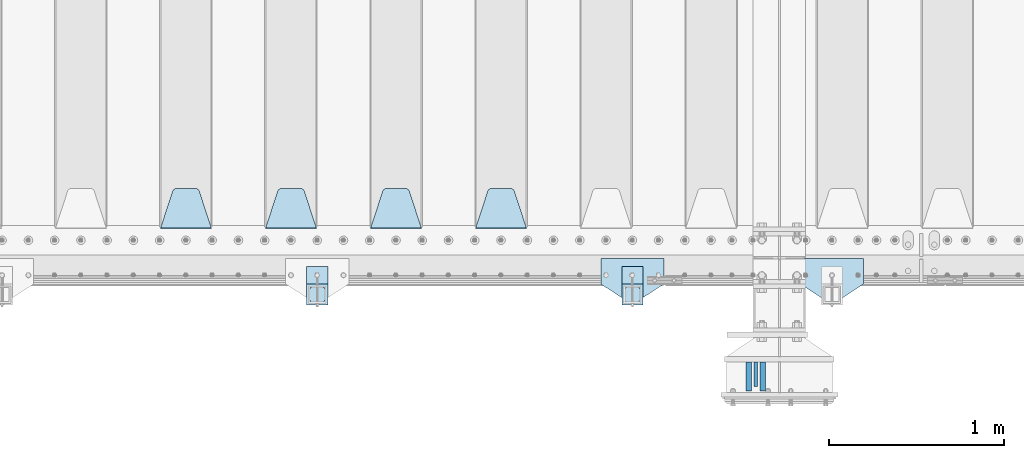
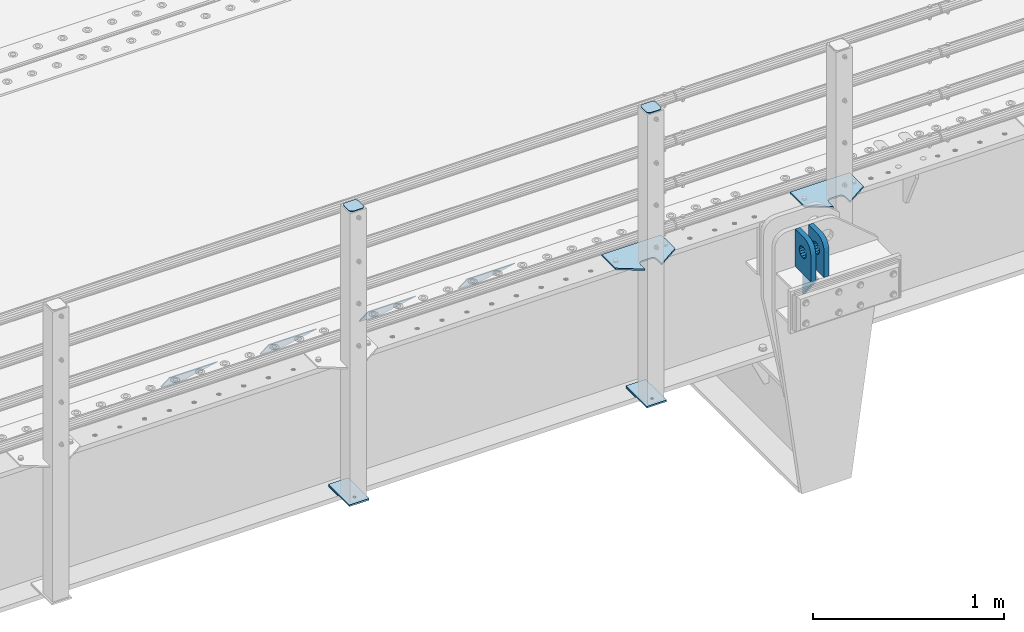
# One storey, part 181 of 219: 15 plates.
"""IFC2X3 building model written with IfcOpenShell, lengths in millimetres."""

from ifc_helpers import new_model, si_unit, frame, origin_with_axes, place, context, subcontext, project, spatial, faceted_brep, material, type_object, element, save


model = new_model("IFC2X3")

# Units and contexts
model_context = context("Model", 3, precision=1e-05, world=origin_with_axes())
body_context = subcontext(model_context, "Body", "Model", "MODEL_VIEW")
ifc_project = project(units=[si_unit("LENGTHUNIT", "METRE", prefix="MILLI"), si_unit("AREAUNIT", "SQUARE_METRE"), si_unit("VOLUMEUNIT", "CUBIC_METRE"), si_unit("MASSUNIT", "GRAM", prefix="KILO"), si_unit("TIMEUNIT", "SECOND"), si_unit("PLANEANGLEUNIT", "RADIAN"), si_unit("SOLIDANGLEUNIT", "STERADIAN"), si_unit("THERMODYNAMICTEMPERATUREUNIT", "DEGREE_CELSIUS"), si_unit("LUMINOUSINTENSITYUNIT", "LUMEN")], contexts=[model_context])

# Site, building, storey
site_placement = place(None, origin_with_axes())
site = spatial("IfcSite", under=ifc_project, at=site_placement, CompositionType="ELEMENT")
building_placement = place(site_placement, origin_with_axes())
building = spatial("IfcBuilding", under=site, at=building_placement, Name="Standard", CompositionType="ELEMENT")
storey_placement = place(building_placement, origin_with_axes())
storey = spatial("IfcBuildingStorey", under=building, at=storey_placement, Name="Undefined", CompositionType="ELEMENT", Elevation=0.0)

# Plates
ifc_material_1 = material(Name="STEEL/S355N")
plate_type_1 = type_object("IfcPlateType", PredefinedType="NOTDEFINED")
plate_1_placement = place(storey_placement, frame((10294.4999999602, 23404.9999999862, -1.8238333723275e-05), z_axis=(0.0, -1.0, 0.0), x_axis=(0.0, 0.0, 1.0)))
element("IfcPlate", 1, at=plate_1_placement, inside=storey, type_object=plate_type_1, material=ifc_material_1, context=body_context, shape_type="Brep", body=[
    faceted_brep([(113.837049096098, 15.0, 53.8370490960951), (113.837049096098, -15.0, 53.8370490960951), (125.840713002492, -15.0, 45.8164572970854), (125.840713002492, 15.0, 45.8164572970854), (105.816457297082, 15.0, 65.8407130024934), (105.816457297082, -15.0, 65.8407130024934), (103.0, 15.0, 80.0), (103.0, -15.0, 80.0), (105.816457297082, 15.0, 94.1592869975066), (105.816457297082, -15.0, 94.1592869975066), (113.837049096098, 15.0, 106.162950903905), (113.837049096098, -15.0, 106.162950903905), (125.840713002492, 15.0, 114.183542702915), (125.840713002492, -15.0, 114.183542702915), (140.0, 15.0, 117.0), (140.0, -15.0, 117.0), (154.159286997508, 15.0, 114.183542702915), (154.159286997508, -15.0, 114.183542702915), (166.162950903902, 15.0, 106.162950903905), (166.162950903902, -15.0, 106.162950903905), (174.183542702918, 15.0, 94.1592869975066), (174.183542702918, -15.0, 94.1592869975066), (177.0, 15.0, 80.0), (177.0, -15.0, 80.0), (174.183542702918, 15.0, 65.8407130024934), (174.183542702918, -15.0, 65.8407130024934), (166.162950903902, 15.0, 53.8370490960951), (166.162950903902, -15.0, 53.8370490960951), (154.159286997508, 15.0, 45.8164572970854), (154.159286997508, -15.0, 45.8164572970854), (140.0, 15.0, 43.0), (140.0, -15.0, 43.0), (240.0, -15.0, 0.0), (240.001666876698, -15.0000000000018, 94.9959403776193), (237.616787699976, -15.0000000000018, 113.113322498932), (230.624045898169, -15.0000000000018, 129.996116868064), (219.499985670386, -15.0000000000018, 144.49378797986), (205.002693976271, -15.0000000000018, 155.61834267445), (188.120138118986, -15.0000000000018, 162.611660295064), (170.002837349484, -15.0000000000018, 164.99715740146), (0.0, -15.0, 165.0), (0.0, -15.0, 0.0), (0.0, 15.0, 0.0), (240.0, 15.0, 0.0), (240.001666876698, 14.9999999999982, 94.9959403776229), (237.616787699976, 14.9999999999982, 113.113322498932), (230.624045898169, 14.9999999999982, 129.996116868064), (219.499985670386, 14.9999999999982, 144.49378797986), (205.002693976271, 14.9999999999982, 155.61834267445), (188.120138118986, 14.9999999999982, 162.611660295064), (170.002837349484, 14.9999999999982, 164.99715740146), (0.0, 15.0, 165.0)], [[[0, 1, 2, 3]], [[4, 5, 1, 0]], [[6, 7, 5, 4]], [[8, 9, 7, 6]], [[10, 11, 9, 8]], [[12, 13, 11, 10]], [[14, 15, 13, 12]], [[16, 17, 15, 14]], [[18, 19, 17, 16]], [[20, 21, 19, 18]], [[22, 23, 21, 20]], [[24, 25, 23, 22]], [[26, 27, 25, 24]], [[28, 29, 27, 26]], [[30, 31, 29, 28]], [[3, 2, 31, 30]], [[32, 33, 34, 35, 36, 37, 38, 39, 40, 41], [19, 21, 23, 25, 27, 29, 31, 2, 1, 5, 7, 9, 11, 13, 15, 17]], [[32, 41, 42, 43]], [[33, 32, 43, 44]], [[34, 33, 44, 45]], [[35, 34, 45, 46]], [[36, 35, 46, 47]], [[37, 36, 47, 48]], [[38, 37, 48, 49]], [[39, 38, 49, 50]], [[40, 39, 50, 51]], [[41, 40, 51, 42]], [[50, 49, 48, 47, 46, 45, 44, 43, 42, 51], [10, 8, 6, 4, 0, 3, 30, 28, 26, 24, 22, 20, 18, 16, 14, 12]]]),
])
plate_2_placement = place(storey_placement, frame((10214.4999999619, 23404.9999999862, -1.8238333723275e-05), z_axis=(0.0, -1.0, 0.0), x_axis=(0.0, 0.0, 1.0)))
element("IfcPlate", 2, at=plate_2_placement, inside=storey, type_object=plate_type_1, material=ifc_material_1, context=body_context, shape_type="Brep", body=[
    faceted_brep([(113.837049096098, 15.0, 53.8370490960951), (113.837049096098, -15.0, 53.8370490960951), (125.840713002492, -15.0, 45.8164572970854), (125.840713002492, 15.0, 45.8164572970854), (105.816457297082, 15.0, 65.8407130024934), (105.816457297082, -15.0, 65.8407130024934), (103.0, 15.0, 80.0), (103.0, -15.0, 80.0), (105.816457297082, 15.0, 94.1592869975066), (105.816457297082, -15.0, 94.1592869975066), (113.837049096098, 15.0, 106.162950903905), (113.837049096098, -15.0, 106.162950903905), (125.840713002492, 15.0, 114.183542702915), (125.840713002492, -15.0, 114.183542702915), (140.0, 15.0, 117.0), (140.0, -15.0, 117.0), (154.159286997508, 15.0, 114.183542702915), (154.159286997508, -15.0, 114.183542702915), (166.162950903902, 15.0, 106.162950903905), (166.162950903902, -15.0, 106.162950903905), (174.183542702918, 15.0, 94.1592869975066), (174.183542702918, -15.0, 94.1592869975066), (177.0, 15.0, 80.0), (177.0, -15.0, 80.0), (174.183542702918, 15.0, 65.8407130024934), (174.183542702918, -15.0, 65.8407130024934), (166.162950903902, 15.0, 53.8370490960951), (166.162950903902, -15.0, 53.8370490960951), (154.159286997508, 15.0, 45.8164572970854), (154.159286997508, -15.0, 45.8164572970854), (140.0, 15.0, 43.0), (140.0, -15.0, 43.0), (240.0, -15.0, 0.0), (240.0, -15.0, 95.0), (237.614807840235, -15.0, 113.117333157177), (230.621778264911, -15.0, 130.0), (219.497474683058, -15.0, 144.497474683056), (205.0, -15.0, 155.621778264911), (188.117333157176, -15.0, 162.614807840233), (170.0, -15.0, 165.0), (0.0, -15.0, 165.0), (0.0, -15.0, 0.0), (0.0, 15.0, 0.0), (240.0, 15.0, 0.0), (240.0, 15.0, 95.0), (237.614807840235, 15.0, 113.117333157177), (230.621778264911, 15.0, 130.0), (219.497474683058, 15.0, 144.497474683056), (205.0, 15.0, 155.621778264911), (188.117333157176, 15.0, 162.614807840233), (170.0, 15.0, 165.0), (0.0, 15.0, 165.0)], [[[0, 1, 2, 3]], [[4, 5, 1, 0]], [[6, 7, 5, 4]], [[8, 9, 7, 6]], [[10, 11, 9, 8]], [[12, 13, 11, 10]], [[14, 15, 13, 12]], [[16, 17, 15, 14]], [[18, 19, 17, 16]], [[20, 21, 19, 18]], [[22, 23, 21, 20]], [[24, 25, 23, 22]], [[26, 27, 25, 24]], [[28, 29, 27, 26]], [[30, 31, 29, 28]], [[3, 2, 31, 30]], [[32, 33, 34, 35, 36, 37, 38, 39, 40, 41], [19, 21, 23, 25, 27, 29, 31, 2, 1, 5, 7, 9, 11, 13, 15, 17]], [[32, 41, 42, 43]], [[33, 32, 43, 44]], [[34, 33, 44, 45]], [[35, 34, 45, 46]], [[36, 35, 46, 47]], [[37, 36, 47, 48]], [[38, 37, 48, 49]], [[39, 38, 49, 50]], [[40, 39, 50, 51]], [[41, 40, 51, 42]], [[50, 49, 48, 47, 46, 45, 44, 43, 42, 51], [10, 8, 6, 4, 0, 3, 30, 28, 26, 24, 22, 20, 18, 16, 14, 12]]]),
])
plate_type_2 = type_object("IfcPlateType", PredefinedType="NOTDEFINED")
plate_3_placement = place(storey_placement, frame((10254.4999999618, 23264.9999999862, -14.000018238301), z_axis=(0.0, 0.0, -1.0), x_axis=(0.0, 1.0, 0.0)))
element("IfcPlate", 3, at=plate_3_placement, inside=storey, type_object=plate_type_2, material=ifc_material_1, context=body_context, shape_type="Brep", body=[
    faceted_brep([(0.0, -10.0, 0.0), (140.0, -10.0, 180.0), (140.0, 10.0, 180.0), (0.0, 10.0, 0.0), (140.0, -10.0, -1.81898940354586e-12), (140.0, 10.0, -1.81898940354586e-12)], [[[0, 1, 2, 3]], [[1, 4, 5, 2]], [[4, 0, 3, 5]], [[5, 3, 2]], [[4, 1, 0]]]),
])
plate_type_3 = type_object("IfcPlateType", PredefinedType="NOTDEFINED")
plate_4_placement = place(storey_placement, frame((8945.0, 24168.232233047, -1.76776695296758), z_axis=(0.0, 0.707106781186547, -0.707106781186548), x_axis=(-1.0, 0.0, 0.0)))
element("IfcPlate", 4, at=plate_4_placement, inside=storey, type_object=plate_type_3, material=ifc_material_1, context=body_context, shape_type="Brep", body=[
    faceted_brep([(0.0, -2.5, 0.0), (69.345504679477, -2.5, 300.171731424834), (69.345504679477, 2.49999999999636, 300.171731424831), (0.0, 2.5, 0.0), (70.9274061199576, -2.50000000000364, 304.8974424154), (70.9274061199576, 2.49999999999636, 304.8974424154), (73.3818627772307, -2.50000000000364, 309.234538108532), (73.3818627772307, 2.49999999999636, 309.234538108532), (76.6187032999569, -2.50000000000364, 313.023683126106), (76.6187032999569, 2.49999999999636, 313.023683126106), (80.5190132704993, -2.50000000000364, 316.125672595372), (80.5190132704993, 2.49999999999636, 316.125672595372), (84.9395038596831, -2.50000000000364, 318.426546230476), (84.9395038596831, 2.5, 318.426546230479), (89.7177759439237, -2.50000000000364, 319.841774983277), (89.7177759439237, 2.5, 319.841774983281), (94.6782862926502, -2.50000000000364, 320.319366455078), (94.6782862926502, 2.49999999999636, 320.319366455078), (195.32171370735, -2.50000000000364, 320.319366455078), (195.32171370735, 2.49999999999636, 320.319366455078), (200.282224056076, -2.50000000000364, 319.841774983277), (200.282224056076, 2.5, 319.841774983281), (205.060496140317, -2.50000000000364, 318.426546230476), (205.060496140317, 2.49999999999636, 318.426546230476), (209.480986729501, -2.50000000000364, 316.125672595372), (209.480986729501, 2.49999999999636, 316.125672595372), (213.381296700043, -2.50000000000364, 313.023683126106), (213.381296700043, 2.49999999999272, 313.023683126106), (216.618137222769, -2.50000000000364, 309.234538108529), (216.618137222769, 2.49999999999636, 309.234538108525), (219.072593880042, -2.50000000000364, 304.8974424154), (219.072593880042, 2.49999999999636, 304.8974424154), (220.654495320523, -2.5, 300.171731424834), (220.654495320523, 2.49999999999636, 300.171731424831), (290.0, -2.50000000000364, 3.63797880709171e-12), (290.0, 2.49999999999636, 0.0)], [[[0, 1, 2, 3]], [[1, 4, 5, 2]], [[4, 6, 7, 5]], [[6, 8, 9, 7]], [[8, 10, 11, 9]], [[10, 12, 13, 11]], [[12, 14, 15, 13]], [[14, 16, 17, 15]], [[16, 18, 19, 17]], [[18, 20, 21, 19]], [[20, 22, 23, 21]], [[22, 24, 25, 23]], [[24, 26, 27, 25]], [[26, 28, 29, 27]], [[28, 30, 31, 29]], [[30, 32, 33, 31]], [[32, 34, 35, 33]], [[34, 0, 3, 35]], [[5, 7, 9, 11, 13, 15, 17, 19, 21, 23, 25, 27, 29, 31, 33, 35, 3, 2]], [[34, 32, 30, 28, 26, 24, 22, 20, 18, 16, 14, 12, 10, 8, 6, 4, 1, 0]]]),
])
plate_5_placement = place(storey_placement, frame((8345.0, 24168.232233047, -1.76776695296758), z_axis=(0.0, 0.707106781186547, -0.707106781186548), x_axis=(-1.0, 0.0, 0.0)))
element("IfcPlate", 5, at=plate_5_placement, inside=storey, type_object=plate_type_3, material=ifc_material_1, context=body_context, shape_type="Brep", body=[
    faceted_brep([(0.0, -2.5, 0.0), (69.345504679477, -2.5, 300.171731424834), (69.345504679477, 2.49999999999636, 300.171731424831), (0.0, 2.5, 0.0), (70.9274061199576, -2.50000000000364, 304.8974424154), (70.9274061199576, 2.49999999999636, 304.8974424154), (73.3818627772307, -2.50000000000364, 309.234538108532), (73.3818627772307, 2.49999999999636, 309.234538108532), (76.6187032999569, -2.50000000000364, 313.023683126106), (76.6187032999569, 2.49999999999636, 313.023683126106), (80.5190132704993, -2.50000000000364, 316.125672595372), (80.5190132704993, 2.49999999999636, 316.125672595372), (84.9395038596831, -2.50000000000364, 318.426546230476), (84.9395038596831, 2.5, 318.426546230479), (89.7177759439237, -2.50000000000364, 319.841774983277), (89.7177759439237, 2.5, 319.841774983281), (94.6782862926502, -2.50000000000364, 320.319366455078), (94.6782862926502, 2.49999999999636, 320.319366455078), (195.32171370735, -2.50000000000364, 320.319366455078), (195.32171370735, 2.49999999999636, 320.319366455078), (200.282224056076, -2.50000000000364, 319.841774983277), (200.282224056076, 2.5, 319.841774983281), (205.060496140317, -2.50000000000364, 318.426546230476), (205.060496140317, 2.49999999999636, 318.426546230476), (209.480986729501, -2.50000000000364, 316.125672595372), (209.480986729501, 2.49999999999636, 316.125672595372), (213.381296700043, -2.50000000000364, 313.023683126106), (213.381296700043, 2.49999999999272, 313.023683126106), (216.618137222769, -2.50000000000364, 309.234538108529), (216.618137222769, 2.49999999999636, 309.234538108525), (219.072593880042, -2.50000000000364, 304.8974424154), (219.072593880042, 2.49999999999636, 304.8974424154), (220.654495320523, -2.5, 300.171731424834), (220.654495320523, 2.49999999999636, 300.171731424831), (290.0, -2.50000000000364, 3.63797880709171e-12), (290.0, 2.49999999999636, 0.0)], [[[0, 1, 2, 3]], [[1, 4, 5, 2]], [[4, 6, 7, 5]], [[6, 8, 9, 7]], [[8, 10, 11, 9]], [[10, 12, 13, 11]], [[12, 14, 15, 13]], [[14, 16, 17, 15]], [[16, 18, 19, 17]], [[18, 20, 21, 19]], [[20, 22, 23, 21]], [[22, 24, 25, 23]], [[24, 26, 27, 25]], [[26, 28, 29, 27]], [[28, 30, 31, 29]], [[30, 32, 33, 31]], [[32, 34, 35, 33]], [[34, 0, 3, 35]], [[5, 7, 9, 11, 13, 15, 17, 19, 21, 23, 25, 27, 29, 31, 33, 35, 3, 2]], [[34, 32, 30, 28, 26, 24, 22, 20, 18, 16, 14, 12, 10, 8, 6, 4, 1, 0]]]),
])
plate_6_placement = place(storey_placement, frame((7745.0, 24168.232233047, -1.76776695296758), z_axis=(0.0, 0.707106781186547, -0.707106781186548), x_axis=(-1.0, 0.0, 0.0)))
element("IfcPlate", 6, at=plate_6_placement, inside=storey, type_object=plate_type_3, material=ifc_material_1, context=body_context, shape_type="Brep", body=[
    faceted_brep([(0.0, -2.5, 0.0), (69.345504679477, -2.5, 300.171731424834), (69.345504679477, 2.49999999999636, 300.171731424831), (0.0, 2.5, 0.0), (70.9274061199576, -2.50000000000364, 304.8974424154), (70.9274061199576, 2.49999999999636, 304.8974424154), (73.3818627772307, -2.50000000000364, 309.234538108532), (73.3818627772307, 2.49999999999636, 309.234538108532), (76.6187032999569, -2.50000000000364, 313.023683126106), (76.6187032999569, 2.49999999999636, 313.023683126106), (80.5190132704993, -2.50000000000364, 316.125672595372), (80.5190132704993, 2.49999999999636, 316.125672595372), (84.9395038596831, -2.50000000000364, 318.426546230476), (84.9395038596831, 2.5, 318.426546230479), (89.7177759439237, -2.50000000000364, 319.841774983277), (89.7177759439237, 2.5, 319.841774983281), (94.6782862926502, -2.50000000000364, 320.319366455078), (94.6782862926502, 2.49999999999636, 320.319366455078), (195.32171370735, -2.50000000000364, 320.319366455078), (195.32171370735, 2.49999999999636, 320.319366455078), (200.282224056076, -2.50000000000364, 319.841774983277), (200.282224056076, 2.5, 319.841774983281), (205.060496140317, -2.50000000000364, 318.426546230476), (205.060496140317, 2.49999999999636, 318.426546230476), (209.480986729501, -2.50000000000364, 316.125672595372), (209.480986729501, 2.49999999999636, 316.125672595372), (213.381296700043, -2.50000000000364, 313.023683126106), (213.381296700043, 2.49999999999272, 313.023683126106), (216.618137222769, -2.50000000000364, 309.234538108529), (216.618137222769, 2.49999999999636, 309.234538108525), (219.072593880042, -2.50000000000364, 304.8974424154), (219.072593880042, 2.49999999999636, 304.8974424154), (220.654495320523, -2.5, 300.171731424834), (220.654495320523, 2.49999999999636, 300.171731424831), (290.0, -2.50000000000364, 3.63797880709171e-12), (290.0, 2.49999999999636, 0.0)], [[[0, 1, 2, 3]], [[1, 4, 5, 2]], [[4, 6, 7, 5]], [[6, 8, 9, 7]], [[8, 10, 11, 9]], [[10, 12, 13, 11]], [[12, 14, 15, 13]], [[14, 16, 17, 15]], [[16, 18, 19, 17]], [[18, 20, 21, 19]], [[20, 22, 23, 21]], [[22, 24, 25, 23]], [[24, 26, 27, 25]], [[26, 28, 29, 27]], [[28, 30, 31, 29]], [[30, 32, 33, 31]], [[32, 34, 35, 33]], [[34, 0, 3, 35]], [[5, 7, 9, 11, 13, 15, 17, 19, 21, 23, 25, 27, 29, 31, 33, 35, 3, 2]], [[34, 32, 30, 28, 26, 24, 22, 20, 18, 16, 14, 12, 10, 8, 6, 4, 1, 0]]]),
])
plate_7_placement = place(storey_placement, frame((7145.0, 24168.232233047, -1.76776695296758), z_axis=(0.0, 0.707106781186547, -0.707106781186548), x_axis=(-1.0, 0.0, 0.0)))
element("IfcPlate", 7, at=plate_7_placement, inside=storey, type_object=plate_type_3, material=ifc_material_1, context=body_context, shape_type="Brep", body=[
    faceted_brep([(0.0, -2.5, 0.0), (69.345504679477, -2.5, 300.171731424834), (69.345504679477, 2.49999999999636, 300.171731424831), (0.0, 2.5, 0.0), (70.9274061199576, -2.50000000000364, 304.8974424154), (70.9274061199576, 2.49999999999636, 304.8974424154), (73.3818627772307, -2.50000000000364, 309.234538108532), (73.3818627772307, 2.49999999999636, 309.234538108532), (76.6187032999569, -2.50000000000364, 313.023683126106), (76.6187032999569, 2.49999999999636, 313.023683126106), (80.5190132704993, -2.50000000000364, 316.125672595372), (80.5190132704993, 2.49999999999636, 316.125672595372), (84.9395038596831, -2.50000000000364, 318.426546230476), (84.9395038596831, 2.5, 318.426546230479), (89.7177759439237, -2.50000000000364, 319.841774983277), (89.7177759439237, 2.5, 319.841774983281), (94.6782862926502, -2.50000000000364, 320.319366455078), (94.6782862926502, 2.49999999999636, 320.319366455078), (195.32171370735, -2.50000000000364, 320.319366455078), (195.32171370735, 2.49999999999636, 320.319366455078), (200.282224056076, -2.50000000000364, 319.841774983277), (200.282224056076, 2.5, 319.841774983281), (205.060496140317, -2.50000000000364, 318.426546230476), (205.060496140317, 2.49999999999636, 318.426546230476), (209.480986729501, -2.50000000000364, 316.125672595372), (209.480986729501, 2.49999999999636, 316.125672595372), (213.381296700043, -2.50000000000364, 313.023683126106), (213.381296700043, 2.49999999999272, 313.023683126106), (216.618137222769, -2.50000000000364, 309.234538108529), (216.618137222769, 2.49999999999636, 309.234538108525), (219.072593880042, -2.50000000000364, 304.8974424154), (219.072593880042, 2.49999999999636, 304.8974424154), (220.654495320523, -2.5, 300.171731424834), (220.654495320523, 2.49999999999636, 300.171731424831), (290.0, -2.50000000000364, 3.63797880709171e-12), (290.0, 2.49999999999636, 0.0)], [[[0, 1, 2, 3]], [[1, 4, 5, 2]], [[4, 6, 7, 5]], [[6, 8, 9, 7]], [[8, 10, 11, 9]], [[10, 12, 13, 11]], [[12, 14, 15, 13]], [[14, 16, 17, 15]], [[16, 18, 19, 17]], [[18, 20, 21, 19]], [[20, 22, 23, 21]], [[22, 24, 25, 23]], [[24, 26, 27, 25]], [[26, 28, 29, 27]], [[28, 30, 31, 29]], [[30, 32, 33, 31]], [[32, 34, 35, 33]], [[34, 0, 3, 35]], [[5, 7, 9, 11, 13, 15, 17, 19, 21, 23, 25, 27, 29, 31, 33, 35, 3, 2]], [[34, 32, 30, 28, 26, 24, 22, 20, 18, 16, 14, 12, 10, 8, 6, 4, 1, 0]]]),
])
ifc_material_2 = material(Name="STEEL/S355J2")
plate_type_4 = type_object("IfcPlateType", PredefinedType="NOTDEFINED")
plate_8_placement = place(storey_placement, frame((10870.0, 23995.0, 5.00000000004911), z_axis=(0.0, -1.0, 0.0), x_axis=(-1.0, 0.0, 0.0)))
element("IfcPlate", 8, at=plate_8_placement, inside=storey, type_object=plate_type_4, material=ifc_material_2, context=body_context, shape_type="Brep", body=[
    faceted_brep([(0.0, -5.0, 0.0), (2.31396552408114e-06, -5.0, 145.0), (2.31396552408114e-06, 5.0, 145.0), (0.0, 5.0, 0.0), (130.0, -5.0, 230.0), (130.0, 5.0, 230.0), (130.0, -5.0, 180.0), (130.0, 5.0, 180.0), (130.48036798992, -5.0, 175.122741949599), (130.48036798992, 5.0, 175.122741949599), (131.903011687218, -5.0, 170.432914190875), (131.903011687218, 5.0, 170.432914190875), (134.213259692437, -5.0, 166.110744174512), (134.213259692437, 5.0, 166.110744174512), (137.322330470337, -5.0, 162.322330470335), (137.322330470337, 5.0, 162.322330470335), (141.11074417451, -5.0, 159.213259692435), (141.11074417451, 5.0, 159.213259692435), (145.432914190873, -5.0, 156.903011687216), (145.432914190873, 5.0, 156.903011687216), (150.122741949597, -5.0, 155.48036798992), (150.122741949597, 5.0, 155.48036798992), (155.0, -5.0, 155.0), (155.0, 5.0, 155.0), (205.0, -5.0, 155.0), (205.0, 5.0, 155.0), (209.877258050403, -5.0, 155.48036798992), (209.877258050403, 5.0, 155.48036798992), (214.567085809127, -5.0, 156.903011687216), (214.567085809127, 5.0, 156.903011687216), (218.88925582549, -5.0, 159.213259692435), (218.88925582549, 5.0, 159.213259692435), (222.677669529663, -5.0, 162.322330470335), (222.677669529663, 5.0, 162.322330470335), (225.786740307563, -5.0, 166.110744174512), (225.786740307563, 5.0, 166.110744174512), (228.096988312782, -5.0, 170.432914190875), (228.096988312782, 5.0, 170.432914190875), (229.51963201008, -5.0, 175.122741949599), (229.51963201008, 5.0, 175.122741949599), (230.0, -5.0, 180.0), (230.0, 5.0, 180.0), (230.0, -5.0, 230.0), (230.0, 5.0, 230.0), (360.0, -5.0, 145.0), (360.0, 5.0, 145.0), (360.0, -5.0, -7.27595761418343e-12), (360.0, 5.0, -7.27595761418343e-12)], [[[0, 1, 2, 3]], [[1, 4, 5, 2]], [[4, 6, 7, 5]], [[6, 8, 9, 7]], [[8, 10, 11, 9]], [[10, 12, 13, 11]], [[12, 14, 15, 13]], [[14, 16, 17, 15]], [[16, 18, 19, 17]], [[18, 20, 21, 19]], [[20, 22, 23, 21]], [[22, 24, 25, 23]], [[24, 26, 27, 25]], [[26, 28, 29, 27]], [[28, 30, 31, 29]], [[30, 32, 33, 31]], [[32, 34, 35, 33]], [[34, 36, 37, 35]], [[36, 38, 39, 37]], [[38, 40, 41, 39]], [[40, 42, 43, 41]], [[42, 44, 45, 43]], [[44, 46, 47, 45]], [[46, 0, 3, 47]], [[5, 7, 9, 11, 13, 15, 17, 19, 21, 23, 25, 27, 29, 31, 33, 35, 37, 39, 41, 43, 45, 47, 3, 2]], [[46, 44, 42, 40, 38, 36, 34, 32, 30, 28, 26, 24, 22, 20, 18, 16, 14, 12, 10, 8, 6, 4, 1, 0]]]),
])
plate_9_placement = place(storey_placement, frame((9730.0, 23995.0, 5.00000000004911), z_axis=(0.0, -1.0, 0.0), x_axis=(-1.0, 0.0, 0.0)))
element("IfcPlate", 9, at=plate_9_placement, inside=storey, type_object=plate_type_4, material=ifc_material_2, context=body_context, shape_type="Brep", body=[
    faceted_brep([(0.0, -5.0, 0.0), (2.31396552408114e-06, -5.0, 145.0), (2.31396552408114e-06, 5.0, 145.0), (0.0, 5.0, 0.0), (130.0, -5.0, 230.0), (130.0, 5.0, 230.0), (130.0, -5.0, 180.0), (130.0, 5.0, 180.0), (130.48036798992, -5.0, 175.122741949599), (130.48036798992, 5.0, 175.122741949599), (131.903011687218, -5.0, 170.432914190875), (131.903011687218, 5.0, 170.432914190875), (134.213259692437, -5.0, 166.110744174512), (134.213259692437, 5.0, 166.110744174512), (137.322330470337, -5.0, 162.322330470335), (137.322330470337, 5.0, 162.322330470335), (141.11074417451, -5.0, 159.213259692435), (141.11074417451, 5.0, 159.213259692435), (145.432914190873, -5.0, 156.903011687216), (145.432914190873, 5.0, 156.903011687216), (150.122741949597, -5.0, 155.48036798992), (150.122741949597, 5.0, 155.48036798992), (155.0, -5.0, 155.0), (155.0, 5.0, 155.0), (205.0, -5.0, 155.0), (205.0, 5.0, 155.0), (209.877258050403, -5.0, 155.48036798992), (209.877258050403, 5.0, 155.48036798992), (214.567085809127, -5.0, 156.903011687216), (214.567085809127, 5.0, 156.903011687216), (218.88925582549, -5.0, 159.213259692435), (218.88925582549, 5.0, 159.213259692435), (222.677669529663, -5.0, 162.322330470335), (222.677669529663, 5.0, 162.322330470335), (225.786740307563, -5.0, 166.110744174512), (225.786740307563, 5.0, 166.110744174512), (228.096988312782, -5.0, 170.432914190875), (228.096988312782, 5.0, 170.432914190875), (229.51963201008, -5.0, 175.122741949599), (229.51963201008, 5.0, 175.122741949599), (230.0, -5.0, 180.0), (230.0, 5.0, 180.0), (230.0, -5.0, 230.0), (230.0, 5.0, 230.0), (360.0, -5.0, 145.0), (360.0, 5.0, 145.0), (360.0, -5.0, -7.27595761418343e-12), (360.0, 5.0, -7.27595761418343e-12)], [[[0, 1, 2, 3]], [[1, 4, 5, 2]], [[4, 6, 7, 5]], [[6, 8, 9, 7]], [[8, 10, 11, 9]], [[10, 12, 13, 11]], [[12, 14, 15, 13]], [[14, 16, 17, 15]], [[16, 18, 19, 17]], [[18, 20, 21, 19]], [[20, 22, 23, 21]], [[22, 24, 25, 23]], [[24, 26, 27, 25]], [[26, 28, 29, 27]], [[28, 30, 31, 29]], [[30, 32, 33, 31]], [[32, 34, 35, 33]], [[34, 36, 37, 35]], [[36, 38, 39, 37]], [[38, 40, 41, 39]], [[40, 42, 43, 41]], [[42, 44, 45, 43]], [[44, 46, 47, 45]], [[46, 0, 3, 47]], [[5, 7, 9, 11, 13, 15, 17, 19, 21, 23, 25, 27, 29, 31, 33, 35, 37, 39, 41, 43, 45, 47, 3, 2]], [[46, 44, 42, 40, 38, 36, 34, 32, 30, 28, 26, 24, 22, 20, 18, 16, 14, 12, 10, 8, 6, 4, 1, 0]]]),
])
plate_type_5 = type_object("IfcPlateType", PredefinedType="NOTDEFINED")
for number, where, z_axis, x_axis in (
    (10, (9609.99999999986, 23949.9999999998, -850.000000000002), (0.0, -1.0, 0.0), (-1.0, 0.0, 0.0)),
    (11, (7809.99999999986, 23949.9999999998, -850.000000000002), (0.0, -1.0, 0.0), (-1.0, 0.0, 0.0)),
):
    element("IfcPlate", number, at=place(storey_placement, frame(where, z_axis=z_axis, x_axis=x_axis)), inside=storey, type_object=plate_type_5, material=ifc_material_2, context=body_context, shape_type="Brep", body=[
        faceted_brep([(53.6360389691836, -5.0, 176.363961030467), (53.6360389691836, 5.0, 176.363961030467), (59.9999999998618, 5.0, 178.999999999789), (59.9999999998618, -5.0, 178.999999999789), (66.3639610305399, 5.0, 176.363961030467), (66.3639610305399, -5.0, 176.363961030467), (68.9999999998618, 5.0, 169.999999999789), (68.9999999998618, -5.0, 169.999999999789), (66.3639610305399, 5.0, 163.636038969111), (66.3639610305399, -5.0, 163.636038969111), (59.9999999998618, 5.0, 160.999999999789), (59.9999999998618, -5.0, 160.999999999789), (53.6360389691836, 5.0, 163.636038969111), (53.6360389691836, -5.0, 163.636038969111), (50.9999999998618, 5.0, 169.999999999789), (50.9999999998618, -5.0, 169.999999999789), (120.0, -5.0, 0.0), (120.0, -5.0, 220.0), (0.0, -5.0, 220.0), (0.0, -5.0, 0.0), (0.0, 5.0, 0.0), (120.0, 5.0, 0.0), (120.0, 5.0, 220.0), (0.0, 5.0, 220.0)], [[[0, 1, 2, 3]], [[3, 2, 4, 5]], [[5, 4, 6, 7]], [[7, 6, 8, 9]], [[9, 8, 10, 11]], [[11, 10, 12, 13]], [[13, 12, 14, 15]], [[15, 14, 1, 0]], [[16, 17, 18, 19], [11, 13, 15, 0, 3, 5, 7, 9]], [[16, 19, 20, 21]], [[17, 16, 21, 22]], [[18, 17, 22, 23]], [[19, 18, 23, 20]], [[22, 21, 20, 23], [2, 1, 14, 12, 10, 8, 6, 4]]]),
    ])
plate_type_6 = type_object("IfcPlateType", PredefinedType="NOTDEFINED")
plate_10_placement = place(storey_placement, frame((9505.99999999987, 23833.9999999998, 1012.50000000001), z_axis=(0.0, -1.0, 0.0), x_axis=(1.0, 0.0, 0.0)))
element("IfcPlate", 12, at=plate_10_placement, inside=storey, type_object=plate_type_6, material=ifc_material_2, context=body_context, shape_type="Brep", body=[
    faceted_brep([(0.0, -2.5, 19.0), (0.0, -2.5, 69.0), (0.0, 2.5, 69.0), (0.0, 2.5, 19.0), (0.476369668545885, -2.5, 73.2278977451715), (0.476369668545885, 2.5, 73.2278977451715), (1.88159150985484, -2.5, 77.2437910432345), (1.88159150985484, 2.5, 77.2437910432345), (4.14520183310742, -2.5, 80.8463062353185), (4.14520183310742, 2.5, 80.8463062353185), (7.15369376468334, -2.5, 83.8547981668889), (7.15369376468334, 2.5, 83.8547981668889), (10.7562089567673, -2.5, 86.118408490147), (10.7562089567673, 2.5, 86.118408490147), (14.7721022548303, -2.5, 87.5236303314523), (14.7721022548303, 2.5, 87.5236303314523), (19.0, -2.5, 88.0), (19.0, 2.5, 88.0), (69.0, -2.5, 88.0), (69.0, 2.5, 88.0), (73.2278977451697, -2.5, 87.5236303314523), (73.2278977451697, 2.5, 87.5236303314523), (77.2437910432327, -2.5, 86.118408490147), (77.2437910432327, 2.5, 86.118408490147), (80.8463062353167, -2.5, 83.8547981668889), (80.8463062353167, 2.5, 83.8547981668889), (83.8547981668926, -2.5, 80.8463062353185), (83.8547981668926, 2.5, 80.8463062353185), (86.1184084901452, -2.5, 77.2437910432345), (86.1184084901452, 2.5, 77.2437910432345), (87.5236303314541, -2.5, 73.2278977451715), (87.5236303314541, 2.5, 73.2278977451715), (88.0, -2.5, 69.0), (88.0, 2.5, 69.0), (88.0, -2.5, 19.0), (88.0, 2.5, 19.0), (87.5236303314541, -2.5, 14.7721022548285), (87.5236303314541, 2.5, 14.7721022548285), (86.1184084901452, -2.5, 10.7562089567655), (86.1184084901452, 2.5, 10.7562089567655), (83.8547981668926, -2.5, 7.15369376468152), (83.8547981668926, 2.5, 7.15369376468152), (80.8463062353167, -2.5, 4.14520183311106), (80.8463062353167, 2.5, 4.14520183311106), (77.2437910432345, -2.5, 1.88159150985302), (77.2437910432345, 2.5, 1.88159150985302), (73.2278977451697, -2.5, 0.476369668547704), (73.2278977451697, 2.5, 0.476369668547704), (69.0, -2.5, 0.0), (69.0, 2.5, 0.0), (19.0, -2.5, 0.0), (19.0, 2.5, 0.0), (14.7721022548303, -2.5, 0.476369668547704), (14.7721022548303, 2.5, 0.476369668547704), (10.7562089567673, -2.5, 1.88159150985302), (10.7562089567673, 2.5, 1.88159150985302), (7.15369376468334, -2.5, 4.14520183311106), (7.15369376468334, 2.5, 4.14520183311106), (4.14520183310742, -2.5, 7.15369376468152), (4.14520183310742, 2.5, 7.15369376468152), (1.88159150985484, -2.5, 10.7562089567655), (1.88159150985484, 2.5, 10.7562089567655), (0.476369668545885, -2.5, 14.7721022548285), (0.476369668545885, 2.5, 14.7721022548285)], [[[0, 1, 2, 3]], [[1, 4, 5, 2]], [[4, 6, 7, 5]], [[6, 8, 9, 7]], [[8, 10, 11, 9]], [[10, 12, 13, 11]], [[12, 14, 15, 13]], [[14, 16, 17, 15]], [[16, 18, 19, 17]], [[18, 20, 21, 19]], [[20, 22, 23, 21]], [[22, 24, 25, 23]], [[24, 26, 27, 25]], [[26, 28, 29, 27]], [[28, 30, 31, 29]], [[30, 32, 33, 31]], [[32, 34, 35, 33]], [[34, 36, 37, 35]], [[36, 38, 39, 37]], [[38, 40, 41, 39]], [[40, 42, 43, 41]], [[42, 44, 45, 43]], [[44, 46, 47, 45]], [[46, 48, 49, 47]], [[48, 50, 51, 49]], [[50, 52, 53, 51]], [[52, 54, 55, 53]], [[54, 56, 57, 55]], [[56, 58, 59, 57]], [[58, 60, 61, 59]], [[60, 62, 63, 61]], [[62, 0, 3, 63]], [[5, 7, 9, 11, 13, 15, 17, 19, 21, 23, 25, 27, 29, 31, 33, 35, 37, 39, 41, 43, 45, 47, 49, 51, 53, 55, 57, 59, 61, 63, 3, 2]], [[62, 60, 58, 56, 54, 52, 50, 48, 46, 44, 42, 40, 38, 36, 34, 32, 30, 28, 26, 24, 22, 20, 18, 16, 14, 12, 10, 8, 6, 4, 1, 0]]]),
])
plate_11_placement = place(storey_placement, frame((7705.99999999987, 23833.9999999998, 1012.50000000001), z_axis=(0.0, -1.0, 0.0), x_axis=(1.0, 0.0, 0.0)))
element("IfcPlate", 13, at=plate_11_placement, inside=storey, type_object=plate_type_6, material=ifc_material_2, context=body_context, shape_type="Brep", body=[
    faceted_brep([(0.0, -2.5, 19.0), (0.0, -2.5, 69.0), (0.0, 2.5, 69.0), (0.0, 2.5, 19.0), (0.476369668545885, -2.5, 73.2278977451715), (0.476369668545885, 2.5, 73.2278977451715), (1.88159150985484, -2.5, 77.2437910432345), (1.88159150985484, 2.5, 77.2437910432345), (4.14520183310742, -2.5, 80.8463062353185), (4.14520183310742, 2.5, 80.8463062353185), (7.15369376468334, -2.5, 83.8547981668889), (7.15369376468334, 2.5, 83.8547981668889), (10.7562089567673, -2.5, 86.118408490147), (10.7562089567673, 2.5, 86.118408490147), (14.7721022548303, -2.5, 87.5236303314523), (14.7721022548303, 2.5, 87.5236303314523), (19.0, -2.5, 88.0), (19.0, 2.5, 88.0), (69.0, -2.5, 88.0), (69.0, 2.5, 88.0), (73.2278977451697, -2.5, 87.5236303314523), (73.2278977451697, 2.5, 87.5236303314523), (77.2437910432327, -2.5, 86.118408490147), (77.2437910432327, 2.5, 86.118408490147), (80.8463062353167, -2.5, 83.8547981668889), (80.8463062353167, 2.5, 83.8547981668889), (83.8547981668926, -2.5, 80.8463062353185), (83.8547981668926, 2.5, 80.8463062353185), (86.1184084901452, -2.5, 77.2437910432345), (86.1184084901452, 2.5, 77.2437910432345), (87.5236303314541, -2.5, 73.2278977451715), (87.5236303314541, 2.5, 73.2278977451715), (88.0, -2.5, 69.0), (88.0, 2.5, 69.0), (88.0, -2.5, 19.0), (88.0, 2.5, 19.0), (87.5236303314541, -2.5, 14.7721022548285), (87.5236303314541, 2.5, 14.7721022548285), (86.1184084901452, -2.5, 10.7562089567655), (86.1184084901452, 2.5, 10.7562089567655), (83.8547981668926, -2.5, 7.15369376468152), (83.8547981668926, 2.5, 7.15369376468152), (80.8463062353167, -2.5, 4.14520183311106), (80.8463062353167, 2.5, 4.14520183311106), (77.2437910432345, -2.5, 1.88159150985302), (77.2437910432345, 2.5, 1.88159150985302), (73.2278977451697, -2.5, 0.476369668547704), (73.2278977451697, 2.5, 0.476369668547704), (69.0, -2.5, 0.0), (69.0, 2.5, 0.0), (19.0, -2.5, 0.0), (19.0, 2.5, 0.0), (14.7721022548303, -2.5, 0.476369668547704), (14.7721022548303, 2.5, 0.476369668547704), (10.7562089567673, -2.5, 1.88159150985302), (10.7562089567673, 2.5, 1.88159150985302), (7.15369376468334, -2.5, 4.14520183311106), (7.15369376468334, 2.5, 4.14520183311106), (4.14520183310742, -2.5, 7.15369376468152), (4.14520183310742, 2.5, 7.15369376468152), (1.88159150985484, -2.5, 10.7562089567655), (1.88159150985484, 2.5, 10.7562089567655), (0.476369668545885, -2.5, 14.7721022548285), (0.476369668545885, 2.5, 14.7721022548285)], [[[0, 1, 2, 3]], [[1, 4, 5, 2]], [[4, 6, 7, 5]], [[6, 8, 9, 7]], [[8, 10, 11, 9]], [[10, 12, 13, 11]], [[12, 14, 15, 13]], [[14, 16, 17, 15]], [[16, 18, 19, 17]], [[18, 20, 21, 19]], [[20, 22, 23, 21]], [[22, 24, 25, 23]], [[24, 26, 27, 25]], [[26, 28, 29, 27]], [[28, 30, 31, 29]], [[30, 32, 33, 31]], [[32, 34, 35, 33]], [[34, 36, 37, 35]], [[36, 38, 39, 37]], [[38, 40, 41, 39]], [[40, 42, 43, 41]], [[42, 44, 45, 43]], [[44, 46, 47, 45]], [[46, 48, 49, 47]], [[48, 50, 51, 49]], [[50, 52, 53, 51]], [[52, 54, 55, 53]], [[54, 56, 57, 55]], [[56, 58, 59, 57]], [[58, 60, 61, 59]], [[60, 62, 63, 61]], [[62, 0, 3, 63]], [[5, 7, 9, 11, 13, 15, 17, 19, 21, 23, 25, 27, 29, 31, 33, 35, 37, 39, 41, 43, 45, 47, 49, 51, 53, 55, 57, 59, 61, 63, 3, 2]], [[62, 60, 58, 56, 54, 52, 50, 48, 46, 44, 42, 40, 38, 36, 34, 32, 30, 28, 26, 24, 22, 20, 18, 16, 14, 12, 10, 8, 6, 4, 1, 0]]]),
])
plate_type_7 = type_object("IfcPlateType", PredefinedType="NOTDEFINED")
for number, where, z_axis, x_axis in (
    (14, (9609.99999999986, 23949.9999999998, -857.500000000002), (0.0, -1.0, 0.0), (-1.0, 0.0, 0.0)),
    (15, (7809.99999999986, 23949.9999999998, -857.500000000002), (0.0, -1.0, 0.0), (-1.0, 0.0, 0.0)),
):
    element("IfcPlate", number, at=place(storey_placement, frame(where, z_axis=z_axis, x_axis=x_axis)), inside=storey, type_object=plate_type_7, material=ifc_material_2, context=body_context, shape_type="Brep", body=[
        faceted_brep([(0.0, -2.5, 0.0), (0.0, -2.5, 100.0), (0.0, 2.5, 100.0), (0.0, 2.5, 0.0), (120.0, -2.5, 100.0), (120.0, 2.5, 100.0), (120.0, -2.5, 0.0), (120.0, 2.5, 0.0)], [[[0, 1, 2, 3]], [[1, 4, 5, 2]], [[4, 6, 7, 5]], [[6, 0, 3, 7]], [[5, 7, 3, 2]], [[6, 4, 1, 0]]]),
    ])

save(model, "model.ifc")
